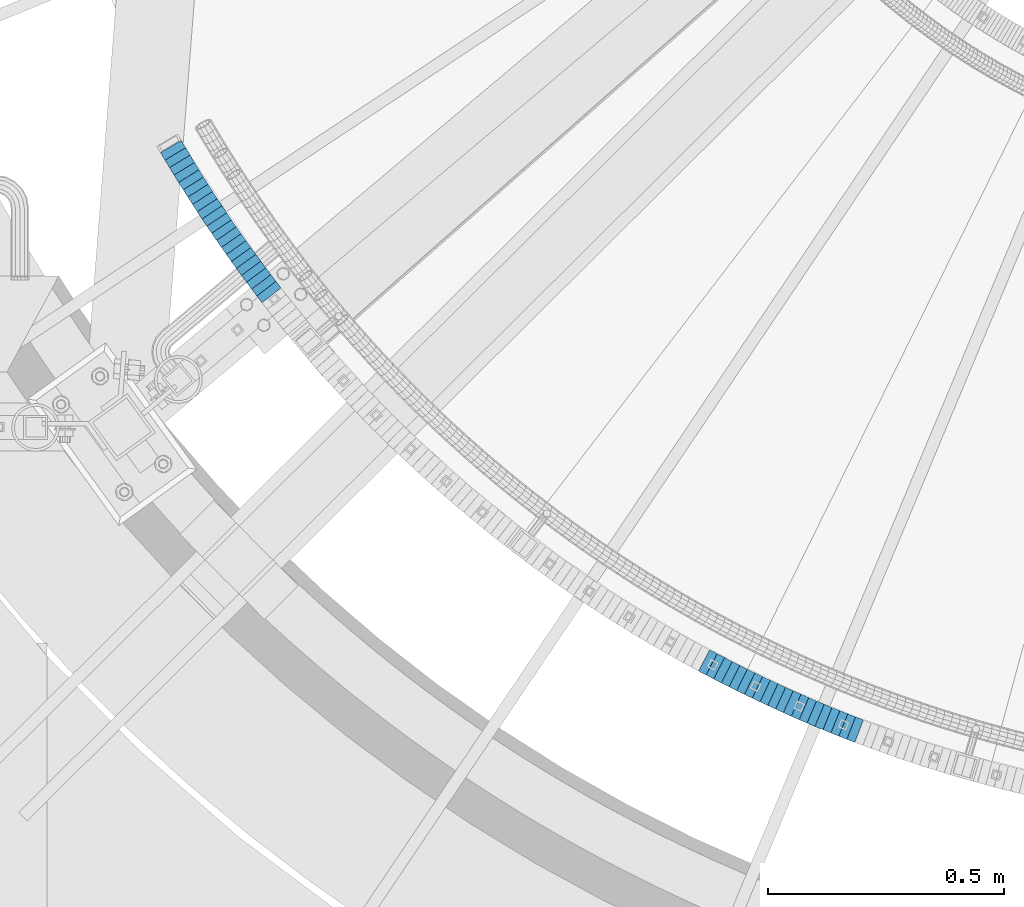
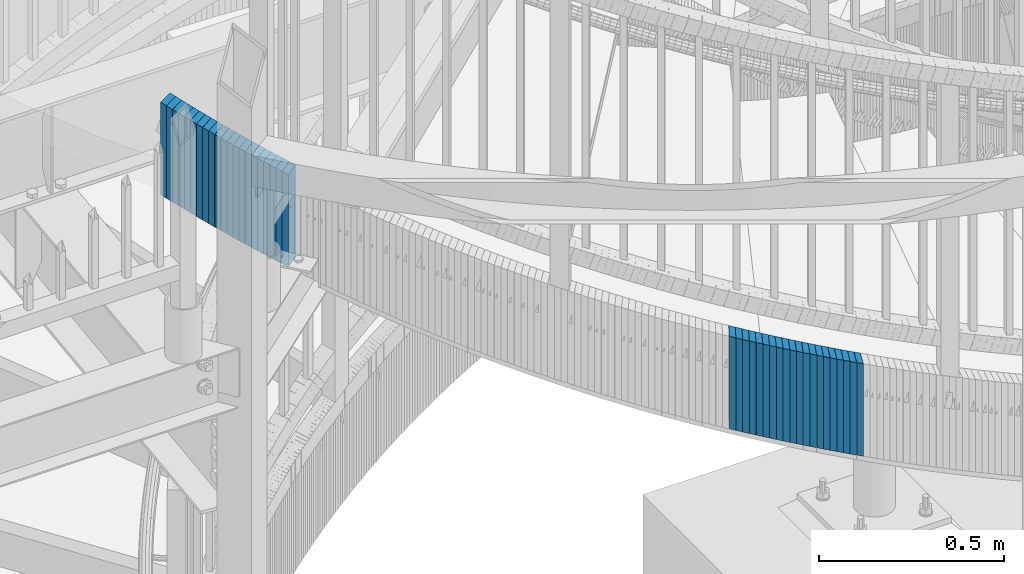
# One storey, part 874 of 975: 41 plates.
"""IFC2X3 building model written with IfcOpenShell, lengths in millimetres."""

from ifc_helpers import new_model, si_unit, frame, origin_with_axes, place, context, subcontext, project, spatial, faceted_brep, material, type_object, element, save


model = new_model("IFC2X3")

# Units and contexts
model_context = context("Model", 3, precision=1e-05, world=origin_with_axes())
body_context = subcontext(model_context, "Body", "Model", "MODEL_VIEW")
ifc_project = project(units=[si_unit("LENGTHUNIT", "METRE", prefix="MILLI"), si_unit("AREAUNIT", "SQUARE_METRE"), si_unit("VOLUMEUNIT", "CUBIC_METRE"), si_unit("MASSUNIT", "GRAM", prefix="KILO"), si_unit("TIMEUNIT", "SECOND"), si_unit("PLANEANGLEUNIT", "RADIAN"), si_unit("SOLIDANGLEUNIT", "STERADIAN"), si_unit("THERMODYNAMICTEMPERATUREUNIT", "DEGREE_CELSIUS"), si_unit("LUMINOUSINTENSITYUNIT", "LUMEN")], contexts=[model_context])

# Site, building, storey
site_placement = place(None, origin_with_axes())
site = spatial("IfcSite", under=ifc_project, at=site_placement, CompositionType="ELEMENT")
building_placement = place(site_placement, origin_with_axes())
building = spatial("IfcBuilding", under=site, at=building_placement, Name="Undefined", CompositionType="ELEMENT")
storey_placement = place(building_placement, origin_with_axes())
storey = spatial("IfcBuildingStorey", under=building, at=storey_placement, Name="Undefined", CompositionType="ELEMENT", Elevation=0.0)

# Plates
ifc_material = material(Name="STEEL/A36")
plate_type = type_object("IfcPlateType", PredefinedType="NOTDEFINED")
plate_1_placement = place(storey_placement, frame((32263.2377787819, 1943.35707548611, 4008.98750006769), z_axis=(-0.50965216587828, 0.860380537794515, 0.0), x_axis=(0.0, 0.0, 1.0)))
element("IfcPlate", 1, at=plate_1_placement, inside=storey, type_object=plate_type, material=ifc_material, Name="WALL", context=body_context, shape_type="Brep", body=[
    faceted_brep([(0.0, -25.3999999999724, -1.81898940354586e-11), (5.80000019073486, -25.3999999999614, 18.2477397918483), (5.80000019073486, 25.3999999999905, 18.247739791881), (0.0, 25.3999999999869, 1.45519152283669e-11), (310.600006103516, -25.3999999999614, 18.2477397918483), (310.600006103516, 25.3999999999905, 18.247739791881), (304.799987792969, -25.3999999999724, -1.81898940354586e-11), (304.799987792969, 25.3999999999869, 1.45519152283669e-11)], [[[0, 1, 2, 3]], [[1, 4, 5, 2]], [[4, 6, 7, 5]], [[6, 0, 3, 7]], [[5, 7, 3, 2]], [[6, 4, 1, 0]]]),
])
plate_2_placement = place(storey_placement, frame((32272.5741913029, 1927.69580112762, 4003.08750006769), z_axis=(-0.512064542174761, 0.858946974293147, 0.0), x_axis=(0.0, 0.0, 1.0)))
element("IfcPlate", 2, at=plate_2_placement, inside=storey, type_object=plate_type, material=ifc_material, Name="WALL", context=body_context, shape_type="Brep", body=[
    faceted_brep([(0.0, -25.3999999999724, -1.81898940354586e-11), (5.90000009536743, -25.4000000000233, 18.1617736816479), (5.90000009536743, 25.4000000000451, 18.1617736816097), (0.0, 25.3999999999869, 1.45519152283669e-11), (310.700012207032, -25.4000000000233, 18.1617736816479), (310.700012207032, 25.4000000000451, 18.1617736816097), (304.799987792969, -25.3999999999724, -1.81898940354586e-11), (304.799987792969, 25.3999999999869, 1.45519152283669e-11)], [[[0, 1, 2, 3]], [[1, 4, 5, 2]], [[4, 6, 7, 5]], [[6, 0, 3, 7]], [[5, 7, 3, 2]], [[6, 4, 1, 0]]]),
])
plate_3_placement = place(storey_placement, frame((32282.2353726493, 1911.92916422109, 3997.28750006769), z_axis=(-0.522562058163781, 0.852601252267221, 0.0), x_axis=(0.0, 0.0, 1.0)))
element("IfcPlate", 3, at=plate_3_placement, inside=storey, type_object=plate_type, material=ifc_material, Name="WALL", context=body_context, shape_type="Brep", body=[
    faceted_brep([(0.0, -25.3999999999724, -1.81898940354586e-11), (5.80000019073486, -25.3999999999687, 18.1796588897505), (5.80000019073486, 25.4000000000233, 18.1796588897596), (0.0, 25.3999999999869, 1.45519152283669e-11), (310.600006103515, -25.3999999999687, 18.1796588897505), (310.600006103515, 25.4000000000233, 18.1796588897596), (304.799987792969, -25.3999999999724, -1.81898940354586e-11), (304.799987792969, 25.3999999999869, 1.45519152283669e-11)], [[[0, 1, 2, 3]], [[1, 4, 5, 2]], [[4, 6, 7, 5]], [[6, 0, 3, 7]], [[5, 7, 3, 2]], [[6, 4, 1, 0]]]),
])
plate_4_placement = place(storey_placement, frame((32291.7737951276, 1896.46667760776, 3991.48750006769), z_axis=(-0.525022161079993, 0.851088556129674, 0.0), x_axis=(0.0, 0.0, 1.0)))
element("IfcPlate", 4, at=plate_4_placement, inside=storey, type_object=plate_type, material=ifc_material, Name="WALL", context=body_context, shape_type="Brep", body=[
    faceted_brep([(0.0, -25.3999999999724, -1.81898940354586e-11), (5.80000019073486, -25.4000000000124, 18.0944747924914), (5.80000019073486, 25.4000000000015, 18.0944747924805), (0.0, 25.3999999999869, 1.45519152283669e-11), (310.600006103516, -25.4000000000124, 18.0944747924914), (310.600006103516, 25.4000000000015, 18.0944747924805), (304.799987792969, -25.3999999999724, -1.81898940354586e-11), (304.799987792969, 25.3999999999869, 1.45519152283669e-11)], [[[0, 1, 2, 3]], [[1, 4, 5, 2]], [[4, 6, 7, 5]], [[6, 0, 3, 7]], [[5, 7, 3, 2]], [[6, 4, 1, 0]]]),
])
plate_5_placement = place(storey_placement, frame((32301.4760215312, 1881.00236729102, 3985.68750006769), z_axis=(-0.531491071246833, 0.847063894393388, 0.0), x_axis=(0.0, 0.0, 1.0)))
element("IfcPlate", 5, at=plate_5_placement, inside=storey, type_object=plate_type, material=ifc_material, Name="WALL", context=body_context, shape_type="Brep", body=[
    faceted_brep([(0.0, -25.3999999999724, -1.81898940354586e-11), (5.80000019073486, -25.4000000000378, 18.0623912811516), (5.80000019073486, 25.4000000000051, 18.0623912811207), (0.0, 25.3999999999869, 1.45519152283669e-11), (310.600006103516, -25.4000000000378, 18.0623912811516), (310.600006103516, 25.4000000000051, 18.0623912811207), (304.799987792969, -25.3999999999724, -1.81898940354586e-11), (304.799987792969, 25.3999999999869, 1.45519152283669e-11)], [[[0, 1, 2, 3]], [[1, 4, 5, 2]], [[4, 6, 7, 5]], [[6, 0, 3, 7]], [[5, 7, 3, 2]], [[6, 4, 1, 0]]]),
])
plate_6_placement = place(storey_placement, frame((32311.2393800325, 1865.60191210266, 3979.88750006769), z_axis=(-0.535445999966163, 0.844569464946629, 0.0), x_axis=(0.0, 0.0, 1.0)))
element("IfcPlate", 6, at=plate_6_placement, inside=storey, type_object=plate_type, material=ifc_material, Name="WALL", context=body_context, shape_type="Brep", body=[
    faceted_brep([(0.0, -25.3999999999724, -1.81898940354586e-11), (5.80000019073486, -25.3999999999614, 18.115739822355), (5.80000019073486, 25.3999999999833, 18.115739822395), (0.0, 25.3999999999869, 1.45519152283669e-11), (310.600006103516, -25.3999999999614, 18.115739822355), (310.600006103516, 25.3999999999833, 18.115739822395), (304.799987792969, -25.3999999999724, -1.81898940354586e-11), (304.799987792969, 25.3999999999869, 1.45519152283669e-11)], [[[0, 1, 2, 3]], [[1, 4, 5, 2]], [[4, 6, 7, 5]], [[6, 0, 3, 7]], [[5, 7, 3, 2]], [[6, 4, 1, 0]]]),
])
plate_7_placement = place(storey_placement, frame((32320.9798611505, 1850.33826958562, 3974.08750006769), z_axis=(-0.537951610922799, 0.842975719879028, 0.0), x_axis=(0.0, 0.0, 1.0)))
element("IfcPlate", 7, at=plate_7_placement, inside=storey, type_object=plate_type, material=ifc_material, Name="WALL", context=body_context, shape_type="Brep", body=[
    faceted_brep([(0.0, -25.3999999999724, -1.81898940354586e-11), (5.80000019073486, -25.4000000000196, 18.0313606262353), (5.80000019073486, 25.3999999999905, 18.0313606262353), (0.0, 25.3999999999869, 1.45519152283669e-11), (310.600006103516, -25.4000000000196, 18.0313606262353), (310.600006103516, 25.3999999999905, 18.0313606262353), (304.799987792969, -25.3999999999724, -1.81898940354586e-11), (304.799987792969, 25.3999999999869, 1.45519152283669e-11)], [[[0, 1, 2, 3]], [[1, 4, 5, 2]], [[4, 6, 7, 5]], [[6, 0, 3, 7]], [[5, 7, 3, 2]], [[6, 4, 1, 0]]]),
])
for number, where, z_axis, x_axis, name in (
    (8, (32331.0497800704, 1834.97558639288, 3968.28750006769), (-0.548293468925575, 0.836285998886482, 0.0), (0.0, 0.0, 1.0), "WALL"),
    (9, (32340.9497800771, 1819.87558639365, 3962.48750006769), (-0.548293468925575, 0.836285998886482, 0.0), (0.0, 0.0, 1.0), "WALL"),
):
    element("IfcPlate", number, at=place(storey_placement, frame(where, z_axis=z_axis, x_axis=x_axis)), inside=storey, type_object=plate_type, material=ifc_material, Name=name, context=body_context, shape_type="Brep", body=[
        faceted_brep([(0.0, -25.3999999999724, -1.81898940354586e-11), (5.80000019073486, -25.4000000000378, 18.0623912811516), (5.80000019073486, 25.4000000000051, 18.0623912811207), (0.0, 25.3999999999869, 1.45519152283669e-11), (310.600006103516, -25.4000000000378, 18.0623912811516), (310.600006103516, 25.4000000000051, 18.0623912811207), (304.799987792969, -25.3999999999724, -1.81898940354586e-11), (304.799987792969, 25.3999999999869, 1.45519152283669e-11)], [[[0, 1, 2, 3]], [[1, 4, 5, 2]], [[4, 6, 7, 5]], [[6, 0, 3, 7]], [[5, 7, 3, 2]], [[6, 4, 1, 0]]]),
    ])
plate_8_placement = place(storey_placement, frame((32350.9355483933, 1804.8456384251, 3956.68750006769), z_axis=(-0.553409530714104, 0.832909293569711, 0.0), x_axis=(0.0, 0.0, 1.0)))
element("IfcPlate", 10, at=plate_8_placement, inside=storey, type_object=plate_type, material=ifc_material, Name="WALL", context=body_context, shape_type="Brep", body=[
    faceted_brep([(0.0, -25.3999999999724, -1.81898940354586e-11), (5.80000019073486, -25.4000000000451, 17.8891029358201), (5.80000019073486, 25.4000000000087, 17.8891029357856), (0.0, 25.3999999999869, 1.45519152283669e-11), (310.600006103516, -25.4000000000451, 17.8891029358201), (310.600006103516, 25.4000000000087, 17.8891029357856), (304.799987792969, -25.3999999999724, -1.81898940354586e-11), (304.799987792969, 25.3999999999869, 1.45519152283669e-11)], [[[0, 1, 2, 3]], [[1, 4, 5, 2]], [[4, 6, 7, 5]], [[6, 0, 3, 7]], [[5, 7, 3, 2]], [[6, 4, 1, 0]]]),
])
plate_9_placement = place(storey_placement, frame((32361.1665378131, 1789.7504581367, 3950.98750006769), z_axis=(-0.561093794018155, 0.827752230026783, 0.0), x_axis=(0.0, 0.0, 1.0)))
element("IfcPlate", 11, at=plate_9_placement, inside=storey, type_object=plate_type, material=ifc_material, Name="WALL", context=body_context, shape_type="Brep", body=[
    faceted_brep([(0.0, -25.3999999999724, -1.81898940354586e-11), (5.69999980926514, -25.4000000000051, 18.0005550384485), (5.69999980926514, 25.3999999999978, 18.0005550384521), (0.0, 25.3999999999869, 1.45519152283669e-11), (310.5, -25.4000000000051, 18.0005550384485), (310.5, 25.3999999999978, 18.0005550384521), (304.799987792969, -25.3999999999724, -1.81898940354586e-11), (304.799987792969, 25.3999999999869, 1.45519152283669e-11)], [[[0, 1, 2, 3]], [[1, 4, 5, 2]], [[4, 6, 7, 5]], [[6, 0, 3, 7]], [[5, 7, 3, 2]], [[6, 4, 1, 0]]]),
])
plate_10_placement = place(storey_placement, frame((32371.3112700105, 1774.88468903055, 3945.18750006769), z_axis=(-0.563683128932899, 0.825991119901671, 0.0), x_axis=(0.0, 0.0, 1.0)))
element("IfcPlate", 12, at=plate_10_placement, inside=storey, type_object=plate_type, material=ifc_material, Name="WALL", context=body_context, shape_type="Brep", body=[
    faceted_brep([(0.0, -25.3999999999724, -1.81898940354586e-11), (5.80000019073486, -25.4000000000233, 17.9178676605334), (5.80000019073486, 25.3999999999942, 17.9178676605297), (0.0, 25.3999999999869, 1.45519152283669e-11), (310.600006103516, -25.4000000000233, 17.9178676605334), (310.600006103516, 25.3999999999942, 17.9178676605297), (304.799987792969, -25.3999999999724, -1.81898940354586e-11), (304.799987792969, 25.3999999999869, 1.45519152283669e-11)], [[[0, 1, 2, 3]], [[1, 4, 5, 2]], [[4, 6, 7, 5]], [[6, 0, 3, 7]], [[5, 7, 3, 2]], [[6, 4, 1, 0]]]),
])
plate_11_placement = place(storey_placement, frame((32381.6231063712, 1760.02216918971, 3939.48750006769), z_axis=(-0.570081547875678, 0.821588113820832, 0.0), x_axis=(0.0, 0.0, 1.0)))
element("IfcPlate", 13, at=plate_11_placement, inside=storey, type_object=plate_type, material=ifc_material, Name="WALL", context=body_context, shape_type="Brep", body=[
    faceted_brep([(0.0, -25.3999999999724, -1.81898940354586e-11), (5.69999980926514, -25.3999999999614, 17.8921775817616), (5.69999980926514, 25.400000000016, 17.8921775817726), (0.0, 25.3999999999869, 1.45519152283669e-11), (310.5, -25.3999999999614, 17.8921775817616), (310.5, 25.400000000016, 17.8921775817726), (304.799987792969, -25.3999999999724, -1.81898940354586e-11), (304.799987792969, 25.3999999999869, 1.45519152283669e-11)], [[[0, 1, 2, 3]], [[1, 4, 5, 2]], [[4, 6, 7, 5]], [[6, 0, 3, 7]], [[5, 7, 3, 2]], [[6, 4, 1, 0]]]),
])
plate_12_placement = place(storey_placement, frame((32391.9896039156, 1745.22680122843, 3933.68750006769), z_axis=(-0.573836192016333, 0.818970100023312, 0.0), x_axis=(0.0, 0.0, 1.0)))
element("IfcPlate", 14, at=plate_12_placement, inside=storey, type_object=plate_type, material=ifc_material, Name="WALL", context=body_context, shape_type="Brep", body=[
    faceted_brep([(0.0, -25.3999999999724, -1.81898940354586e-11), (5.80000019073486, -25.399999999976, 17.9493732452247), (5.80000019073486, 25.4000000000051, 17.9493732452393), (0.0, 25.3999999999869, 1.45519152283669e-11), (310.600006103516, -25.399999999976, 17.9493732452247), (310.600006103516, 25.4000000000051, 17.9493732452393), (304.799987792969, -25.3999999999724, -1.81898940354586e-11), (304.799987792969, 25.3999999999869, 1.45519152283669e-11)], [[[0, 1, 2, 3]], [[1, 4, 5, 2]], [[4, 6, 7, 5]], [[6, 0, 3, 7]], [[5, 7, 3, 2]], [[6, 4, 1, 0]]]),
])
for number, where, z_axis, x_axis, name in (
    (15, (32402.5515073453, 1730.49842355585, 3927.98750006769), (-0.582827439183217, 0.812595948879351, 7.00201781000943e-11), (0.0, 0.0, 1.0), "WALL"),
    (16, (32412.9515073392, 1715.99842355673, 3922.28750006769), (-0.582827439183217, 0.812595948879351, 7.00201781000943e-11), (0.0, 0.0, 1.0), "WALL"),
):
    element("IfcPlate", number, at=place(storey_placement, frame(where, z_axis=z_axis, x_axis=x_axis)), inside=storey, type_object=plate_type, material=ifc_material, Name=name, context=body_context, shape_type="Brep", body=[
        faceted_brep([(0.0, -25.3999999999724, -1.81898940354586e-11), (5.69999980926514, -25.3999999999651, 17.8440475463649), (5.69999980926514, 25.3999999999942, 17.8440475463904), (0.0, 25.3999999999869, 1.45519152283669e-11), (310.5, -25.3999999999651, 17.8440475463649), (310.5, 25.3999999999942, 17.8440475463904), (304.799987792969, -25.3999999999724, -1.81898940354586e-11), (304.799987792969, 25.3999999999869, 1.45519152283669e-11)], [[[0, 1, 2, 3]], [[1, 4, 5, 2]], [[4, 6, 7, 5]], [[6, 0, 3, 7]], [[5, 7, 3, 2]], [[6, 4, 1, 0]]]),
    ])
plate_13_placement = place(storey_placement, frame((32423.735887595, 1701.34467783482, 3916.58750006769), z_axis=(-0.592817428097409, 0.805336884132332, 0.0), x_axis=(0.0, 0.0, 1.0)))
element("IfcPlate", 17, at=plate_13_placement, inside=storey, type_object=plate_type, material=ifc_material, Name="WALL", context=body_context, shape_type="Brep", body=[
    faceted_brep([(0.0, -25.3999999999724, -1.81898940354586e-11), (5.69999980926514, -25.3999999999687, 17.8807163238307), (5.69999980926514, 25.400000000016, 17.880716323838), (0.0, 25.3999999999869, 1.45519152283669e-11), (310.5, -25.3999999999687, 17.8807163238307), (310.5, 25.400000000016, 17.880716323838), (304.799987792969, -25.3999999999724, -1.81898940354586e-11), (304.799987792969, 25.3999999999869, 1.45519152283669e-11)], [[[0, 1, 2, 3]], [[1, 4, 5, 2]], [[4, 6, 7, 5]], [[6, 0, 3, 7]], [[5, 7, 3, 2]], [[6, 4, 1, 0]]]),
])
plate_14_placement = place(storey_placement, frame((32434.3861484832, 1686.97663649873, 3910.78750006769), z_axis=(-0.595496220844773, 0.80335810879059, 0.0), x_axis=(0.0, 0.0, 1.0)))
element("IfcPlate", 18, at=plate_14_placement, inside=storey, type_object=plate_type, material=ifc_material, Name="WALL", context=body_context, shape_type="Brep", body=[
    faceted_brep([(0.0, -25.3999999999724, -1.81898940354586e-11), (5.80000019073486, -25.4000000000124, 17.8002815246691), (5.80000019073486, 25.4000000000051, 17.8002815246546), (0.0, 25.3999999999869, 1.45519152283669e-11), (310.600006103516, -25.4000000000124, 17.8002815246691), (310.600006103516, 25.4000000000051, 17.8002815246546), (304.799987792969, -25.3999999999724, -1.81898940354586e-11), (304.799987792969, 25.3999999999869, 1.45519152283669e-11)], [[[0, 1, 2, 3]], [[1, 4, 5, 2]], [[4, 6, 7, 5]], [[6, 0, 3, 7]], [[5, 7, 3, 2]], [[6, 4, 1, 0]]]),
])
plate_15_placement = place(storey_placement, frame((32444.9861484776, 1672.67663649869, 3905.08750006769), z_axis=(-0.595496220844773, 0.80335810879059, 0.0), x_axis=(0.0, 0.0, 1.0)))
element("IfcPlate", 19, at=plate_15_placement, inside=storey, type_object=plate_type, material=ifc_material, Name="WALL", context=body_context, shape_type="Brep", body=[
    faceted_brep([(0.0, -25.3999999999724, -1.81898940354586e-11), (5.69999980926514, -25.4000000000196, 17.8002815246764), (5.69999980926514, 25.4000000000015, 17.8002815246618), (0.0, 25.3999999999869, 1.45519152283669e-11), (310.5, -25.4000000000196, 17.8002815246764), (310.5, 25.4000000000015, 17.8002815246618), (304.799987792969, -25.3999999999724, -1.81898940354586e-11), (304.799987792969, 25.3999999999869, 1.45519152283669e-11)], [[[0, 1, 2, 3]], [[1, 4, 5, 2]], [[4, 6, 7, 5]], [[6, 0, 3, 7]], [[5, 7, 3, 2]], [[6, 4, 1, 0]]]),
])
for number, where, z_axis, x_axis, name in (
    (20, (32456.0269395398, 1658.25708780837, 3899.38750006769), (-0.608076877922584, 0.79387814589893, 0.0), (0.0, 0.0, 1.0), "WALL"),
    (21, (32466.8269395445, 1644.15708780927, 3893.68750006769), (-0.608076877922584, 0.79387814589893, 0.0), (0.0, 0.0, 1.0), "WALL"),
):
    element("IfcPlate", number, at=place(storey_placement, frame(where, z_axis=z_axis, x_axis=x_axis)), inside=storey, type_object=plate_type, material=ifc_material, Name=name, context=body_context, shape_type="Brep", body=[
        faceted_brep([(0.0, -25.3999999999724, -1.81898940354586e-11), (5.69999980926514, -25.3999999999542, 17.7609119415029), (5.69999980926514, 25.4000000000051, 17.7609119415283), (0.0, 25.3999999999869, 1.45519152283669e-11), (310.5, -25.3999999999542, 17.7609119415029), (310.5, 25.4000000000051, 17.7609119415283), (304.799987792969, -25.3999999999724, -1.81898940354586e-11), (304.799987792969, 25.3999999999869, 1.45519152283669e-11)], [[[0, 1, 2, 3]], [[1, 4, 5, 2]], [[4, 6, 7, 5]], [[6, 0, 3, 7]], [[5, 7, 3, 2]], [[6, 4, 1, 0]]]),
    ])
plate_16_placement = place(storey_placement, frame((33398.2790854262, 863.016063138942, 3504.3875000677), z_axis=(-0.885282574950683, 0.465053504974092, 0.0), x_axis=(0.0, 0.0, 1.0)))
element("IfcPlate", 22, at=plate_16_placement, inside=storey, type_object=plate_type, material=ifc_material, Name="WALL", context=body_context, shape_type="Brep", body=[
    faceted_brep([(0.0, -25.3999999999724, -1.81898940354586e-11), (5.69999980926514, -25.4000000000196, 17.8538513183848), (5.69999980926514, 25.4000000000415, 17.8538513183157), (0.0, 25.3999999999869, 1.45519152283669e-11), (310.5, -25.4000000000196, 17.8538513183848), (310.5, 25.4000000000415, 17.8538513183157), (304.799987792969, -25.3999999999724, -1.81898940354586e-11), (304.799987792969, 25.3999999999869, 1.45519152283669e-11)], [[[0, 1, 2, 3]], [[1, 4, 5, 2]], [[4, 6, 7, 5]], [[6, 0, 3, 7]], [[5, 7, 3, 2]], [[6, 4, 1, 0]]]),
])
plate_17_placement = place(storey_placement, frame((33414.2374284231, 854.685511041615, 3498.5875000677), z_axis=(-0.886485413411108, 0.462756536214603, 0.0), x_axis=(0.0, 0.0, 1.0)))
element("IfcPlate", 23, at=plate_17_placement, inside=storey, type_object=plate_type, material=ifc_material, Name="WALL", context=body_context, shape_type="Brep", body=[
    faceted_brep([(0.0, -25.3999999999724, -1.81898940354586e-11), (5.80000019073486, -25.3999999999614, 17.9424076079595), (5.80000019073486, 25.3999999999978, 17.9424076080322), (0.0, 25.3999999999869, 1.45519152283669e-11), (310.600006103516, -25.3999999999614, 17.9424076079595), (310.600006103516, 25.3999999999978, 17.9424076080322), (304.799987792969, -25.3999999999724, -1.81898940354586e-11), (304.799987792969, 25.3999999999869, 1.45519152283669e-11)], [[[0, 1, 2, 3]], [[1, 4, 5, 2]], [[4, 6, 7, 5]], [[6, 0, 3, 7]], [[5, 7, 3, 2]], [[6, 4, 1, 0]]]),
])
for number, where, z_axis, x_axis, name in (
    (24, (33430.2491479755, 846.427543789584, 3492.8875000677), (-0.88876758866203, 0.4583581278257, 0.0), (0.0, 0.0, 1.0), "WALL"),
    (25, (33446.5322191075, 838.283789884843, 3487.1875000677), (-0.894427191199916, 0.447213595099958, 0.0), (0.0, 0.0, 1.0), "WALL"),
):
    element("IfcPlate", number, at=place(storey_placement, frame(where, z_axis=z_axis, x_axis=x_axis)), inside=storey, type_object=plate_type, material=ifc_material, Name=name, context=body_context, shape_type="Brep", body=[
        faceted_brep([(0.0, -25.3999999999724, -1.81898940354586e-11), (5.69999980926514, -25.3999999999614, 17.8921775817616), (5.69999980926514, 25.400000000016, 17.8921775817726), (0.0, 25.3999999999869, 1.45519152283669e-11), (310.5, -25.3999999999614, 17.8921775817616), (310.5, 25.400000000016, 17.8921775817726), (304.799987792969, -25.3999999999724, -1.81898940354586e-11), (304.799987792969, 25.3999999999869, 1.45519152283669e-11)], [[[0, 1, 2, 3]], [[1, 4, 5, 2]], [[4, 6, 7, 5]], [[6, 0, 3, 7]], [[5, 7, 3, 2]], [[6, 4, 1, 0]]]),
    ])
plate_18_placement = place(storey_placement, frame((33462.6887676408, 830.255603483746, 3481.3875000677), z_axis=(-0.895536892069428, 0.444987275034499, 0.0), x_axis=(0.0, 0.0, 1.0)))
element("IfcPlate", 26, at=plate_18_placement, inside=storey, type_object=plate_type, material=ifc_material, Name="WALL", context=body_context, shape_type="Brep", body=[
    faceted_brep([(0.0, -25.3999999999724, -1.81898940354586e-11), (5.80000019073486, -25.3999999999505, 17.9788761138298), (5.80000019073486, 25.4000000000196, 17.9788761138625), (0.0, 25.3999999999869, 1.45519152283669e-11), (310.600006103516, -25.3999999999505, 17.9788761138298), (310.600006103516, 25.4000000000196, 17.9788761138625), (304.799987792969, -25.3999999999724, -1.81898940354586e-11), (304.799987792969, 25.3999999999869, 1.45519152283669e-11)], [[[0, 1, 2, 3]], [[1, 4, 5, 2]], [[4, 6, 7, 5]], [[6, 0, 3, 7]], [[5, 7, 3, 2]], [[6, 4, 1, 0]]]),
])
plate_19_placement = place(storey_placement, frame((33478.9024956787, 822.299446280344, 3475.5875000677), z_axis=(-0.897747805592998, 0.440509792800292, 0.0), x_axis=(0.0, 0.0, 1.0)))
element("IfcPlate", 27, at=plate_19_placement, inside=storey, type_object=plate_type, material=ifc_material, Name="WALL", context=body_context, shape_type="Brep", body=[
    faceted_brep([(0.0, -25.3999999999724, -1.81898940354586e-11), (5.80000019073486, -25.3999999999833, 17.9287471770986), (5.80000019073486, 25.4000000000087, 17.9287471771167), (0.0, 25.3999999999869, 1.45519152283669e-11), (310.600006103516, -25.3999999999833, 17.9287471770986), (310.600006103516, 25.4000000000087, 17.9287471771167), (304.799987792969, -25.3999999999724, -1.81898940354586e-11), (304.799987792969, 25.3999999999869, 1.45519152283669e-11)], [[[0, 1, 2, 3]], [[1, 4, 5, 2]], [[4, 6, 7, 5]], [[6, 0, 3, 7]], [[5, 7, 3, 2]], [[6, 4, 1, 0]]]),
])
plate_20_placement = place(storey_placement, frame((33495.1170648781, 814.443585333223, 3469.8875000677), z_axis=(-0.899947055462653, 0.435999194224142, 0.0), x_axis=(0.0, 0.0, 1.0)))
element("IfcPlate", 28, at=plate_20_placement, inside=storey, type_object=plate_type, material=ifc_material, Name="WALL", context=body_context, shape_type="Brep", body=[
    faceted_brep([(0.0, -25.3999999999724, -1.81898940354586e-11), (5.69999980926514, -25.3999999999614, 17.8921775817616), (5.69999980926514, 25.400000000016, 17.8921775817726), (0.0, 25.3999999999869, 1.45519152283669e-11), (310.5, -25.3999999999614, 17.8921775817616), (310.5, 25.400000000016, 17.8921775817726), (304.799987792969, -25.3999999999724, -1.81898940354586e-11), (304.799987792969, 25.3999999999869, 1.45519152283669e-11)], [[[0, 1, 2, 3]], [[1, 4, 5, 2]], [[4, 6, 7, 5]], [[6, 0, 3, 7]], [[5, 7, 3, 2]], [[6, 4, 1, 0]]]),
])
plate_21_placement = place(storey_placement, frame((33511.4876246874, 806.661736721061, 3464.1875000677), z_axis=(-0.903169441759062, 0.429284240885481, 0.0), x_axis=(0.0, 0.0, 1.0)))
element("IfcPlate", 29, at=plate_21_placement, inside=storey, type_object=plate_type, material=ifc_material, Name="WALL", context=body_context, shape_type="Brep", body=[
    faceted_brep([(0.0, -25.3999999999724, -1.81898940354586e-11), (5.69999980926514, -25.3999999999542, 17.9401779173968), (5.69999980926514, 25.3999999999924, 17.9401779175023), (0.0, 25.3999999999869, 1.45519152283669e-11), (310.5, -25.3999999999542, 17.9401779173968), (310.5, 25.3999999999924, 17.9401779175023), (304.799987792969, -25.3999999999724, -1.81898940354586e-11), (304.799987792969, 25.3999999999869, 1.45519152283669e-11)], [[[0, 1, 2, 3]], [[1, 4, 5, 2]], [[4, 6, 7, 5]], [[6, 0, 3, 7]], [[5, 7, 3, 2]], [[6, 4, 1, 0]]]),
])
plate_22_placement = place(storey_placement, frame((33527.8035510447, 799.00699414613, 3458.3875000677), z_axis=(-0.905324661250481, 0.42472021111751, 0.0), x_axis=(0.0, 0.0, 1.0)))
element("IfcPlate", 30, at=plate_22_placement, inside=storey, type_object=plate_type, material=ifc_material, Name="WALL", context=body_context, shape_type="Brep", body=[
    faceted_brep([(0.0, -25.3999999999724, -1.81898940354586e-11), (5.80000019073486, -25.4000000000451, 17.8891029358201), (5.80000019073486, 25.4000000000087, 17.8891029357856), (0.0, 25.3999999999869, 1.45519152283669e-11), (310.600006103516, -25.4000000000451, 17.8891029358201), (310.600006103516, 25.4000000000087, 17.8891029357856), (304.799987792969, -25.3999999999724, -1.81898940354586e-11), (304.799987792969, 25.3999999999869, 1.45519152283669e-11)], [[[0, 1, 2, 3]], [[1, 4, 5, 2]], [[4, 6, 7, 5]], [[6, 0, 3, 7]], [[5, 7, 3, 2]], [[6, 4, 1, 0]]]),
])
plate_23_placement = place(storey_placement, frame((33544.2743052284, 791.427658079768, 3452.6875000677), z_axis=(-0.908448128430405, 0.417997605198038, 0.0), x_axis=(0.0, 0.0, 1.0)))
element("IfcPlate", 31, at=plate_23_placement, inside=storey, type_object=plate_type, material=ifc_material, Name="WALL", context=body_context, shape_type="Brep", body=[
    faceted_brep([(0.0, -25.3999999999724, -1.81898940354586e-11), (5.69999980926514, -25.3999999999542, 17.9401779173968), (5.69999980926514, 25.3999999999924, 17.9401779175023), (0.0, 25.3999999999869, 1.45519152283669e-11), (310.5, -25.3999999999542, 17.9401779173968), (310.5, 25.3999999999924, 17.9401779175023), (304.799987792969, -25.3999999999724, -1.81898940354586e-11), (304.799987792969, 25.3999999999869, 1.45519152283669e-11)], [[[0, 1, 2, 3]], [[1, 4, 5, 2]], [[4, 6, 7, 5]], [[6, 0, 3, 7]], [[5, 7, 3, 2]], [[6, 4, 1, 0]]]),
])
plate_24_placement = place(storey_placement, frame((33560.5378877091, 783.998508349835, 3446.8875000677), z_axis=(-0.909595755607489, 0.415494357820705, 0.0), x_axis=(0.0, 0.0, 1.0)))
element("IfcPlate", 32, at=plate_24_placement, inside=storey, type_object=plate_type, material=ifc_material, Name="WALL", context=body_context, shape_type="Brep", body=[
    faceted_brep([(0.0, -25.3999999999724, -1.81898940354586e-11), (5.80000019073486, -25.3999999999542, 17.8084259032221), (5.80000019073486, 25.3999999999833, 17.8084259033567), (0.0, 25.3999999999869, 1.45519152283669e-11), (310.600006103516, -25.3999999999542, 17.8084259032221), (310.600006103516, 25.3999999999833, 17.8084259033567), (304.799987792969, -25.3999999999724, -1.81898940354586e-11), (304.799987792969, 25.3999999999869, 1.45519152283669e-11)], [[[0, 1, 2, 3]], [[1, 4, 5, 2]], [[4, 6, 7, 5]], [[6, 0, 3, 7]], [[5, 7, 3, 2]], [[6, 4, 1, 0]]]),
])
plate_25_placement = place(storey_placement, frame((33577.1624007158, 776.597265716418, 3441.1875000677), z_axis=(-0.913581686036451, 0.406655263016225, 0.0), x_axis=(0.0, 0.0, 1.0)))
element("IfcPlate", 33, at=plate_25_placement, inside=storey, type_object=plate_type, material=ifc_material, Name="WALL", context=body_context, shape_type="Brep", body=[
    faceted_brep([(0.0, -25.3999999999724, -1.81898940354586e-11), (5.69999980926514, -25.4000000000342, 17.9493732452938), (5.69999980926514, 25.4000000000415, 17.9493732451738), (0.0, 25.3999999999869, 1.45519152283669e-11), (310.5, -25.4000000000342, 17.9493732452938), (310.5, 25.4000000000415, 17.9493732451738), (304.799987792969, -25.3999999999724, -1.81898940354586e-11), (304.799987792969, 25.3999999999869, 1.45519152283669e-11)], [[[0, 1, 2, 3]], [[1, 4, 5, 2]], [[4, 6, 7, 5]], [[6, 0, 3, 7]], [[5, 7, 3, 2]], [[6, 4, 1, 0]]]),
])
plate_26_placement = place(storey_placement, frame((33593.68089681, 769.344882176379, 3435.4875000677), z_axis=(-0.91564403017333, 0.401990062076095, 0.0), x_axis=(0.0, 0.0, 1.0)))
element("IfcPlate", 34, at=plate_26_placement, inside=storey, type_object=plate_type, material=ifc_material, Name="WALL", context=body_context, shape_type="Brep", body=[
    faceted_brep([(0.0, -25.3999999999724, -1.81898940354586e-11), (5.69999980926514, -25.4000000000633, 17.9075393677485), (5.69999980926514, 25.3999999999905, 17.9075393676903), (0.0, 25.3999999999869, 1.45519152283669e-11), (310.5, -25.4000000000633, 17.9075393677485), (310.5, 25.3999999999905, 17.9075393676903), (304.799987792969, -25.3999999999724, -1.81898940354586e-11), (304.799987792969, 25.3999999999869, 1.45519152283669e-11)], [[[0, 1, 2, 3]], [[1, 4, 5, 2]], [[4, 6, 7, 5]], [[6, 0, 3, 7]], [[5, 7, 3, 2]], [[6, 4, 1, 0]]]),
])
plate_27_placement = place(storey_placement, frame((33610.320288361, 762.241246398534, 3429.6875000677), z_axis=(-0.919724178945735, 0.392565197976837, 0.0), x_axis=(0.0, 0.0, 1.0)))
element("IfcPlate", 35, at=plate_27_placement, inside=storey, type_object=plate_type, material=ifc_material, Name="WALL", context=body_context, shape_type="Brep", body=[
    faceted_brep([(0.0, -25.3999999999724, -1.81898940354586e-11), (5.80000019073486, -25.3999999999796, 17.8280677795228), (5.80000019073486, 25.4000000000196, 17.8280677795265), (0.0, 25.3999999999869, 1.45519152283669e-11), (310.600006103516, -25.3999999999796, 17.8280677795228), (310.600006103516, 25.4000000000196, 17.8280677795265), (304.799987792969, -25.3999999999724, -1.81898940354586e-11), (304.799987792969, 25.3999999999869, 1.45519152283669e-11)], [[[0, 1, 2, 3]], [[1, 4, 5, 2]], [[4, 6, 7, 5]], [[6, 0, 3, 7]], [[5, 7, 3, 2]], [[6, 4, 1, 0]]]),
])
plate_28_placement = place(storey_placement, frame((33626.7202883639, 755.241246399464, 3423.9875000677), z_axis=(-0.919724178945735, 0.392565197976837, 0.0), x_axis=(0.0, 0.0, 1.0)))
element("IfcPlate", 36, at=plate_28_placement, inside=storey, type_object=plate_type, material=ifc_material, Name="WALL", context=body_context, shape_type="Brep", body=[
    faceted_brep([(0.0, -25.3999999999724, -1.81898940354586e-11), (5.69999980926514, -25.3999999999724, 17.833955764745), (5.69999980926514, 25.3999999999905, 17.8339557647923), (0.0, 25.3999999999869, 1.45519152283669e-11), (310.5, -25.3999999999724, 17.833955764745), (310.5, 25.3999999999905, 17.8339557647923), (304.799987792969, -25.3999999999724, -1.81898940354586e-11), (304.799987792969, 25.3999999999869, 1.45519152283669e-11)], [[[0, 1, 2, 3]], [[1, 4, 5, 2]], [[4, 6, 7, 5]], [[6, 0, 3, 7]], [[5, 7, 3, 2]], [[6, 4, 1, 0]]]),
])
plate_29_placement = place(storey_placement, frame((33643.5132413538, 748.318365526468, 3418.2875000677), z_axis=(-0.924562008594262, 0.381031615832787, 0.0), x_axis=(0.0, 0.0, 1.0)))
element("IfcPlate", 37, at=plate_29_placement, inside=storey, type_object=plate_type, material=ifc_material, Name="WALL", context=body_context, shape_type="Brep", body=[
    faceted_brep([(0.0, -25.3999999999724, -1.81898940354586e-11), (5.69999980926514, -25.4000000000196, 17.8538513183848), (5.69999980926514, 25.4000000000415, 17.8538513183157), (0.0, 25.3999999999869, 1.45519152283669e-11), (310.5, -25.4000000000196, 17.8538513183848), (310.5, 25.4000000000415, 17.8538513183157), (304.799987792969, -25.3999999999724, -1.81898940354586e-11), (304.799987792969, 25.3999999999869, 1.45519152283669e-11)], [[[0, 1, 2, 3]], [[1, 4, 5, 2]], [[4, 6, 7, 5]], [[6, 0, 3, 7]], [[5, 7, 3, 2]], [[6, 4, 1, 0]]]),
])
plate_30_placement = place(storey_placement, frame((33660.1631445129, 741.497861356481, 3412.4875000677), z_axis=(-0.925369259401997, 0.379066925164674, 0.0), x_axis=(0.0, 0.0, 1.0)))
element("IfcPlate", 38, at=plate_30_placement, inside=storey, type_object=plate_type, material=ifc_material, Name="WALL", context=body_context, shape_type="Brep", body=[
    faceted_brep([(0.0, -25.3999999999724, -1.81898940354586e-11), (5.80000019073486, -25.3999999999614, 17.9424076079595), (5.80000019073486, 25.3999999999978, 17.9424076080322), (0.0, 25.3999999999869, 1.45519152283669e-11), (310.600006103516, -25.3999999999614, 17.9424076079595), (310.600006103516, 25.3999999999978, 17.9424076080322), (304.799987792969, -25.3999999999724, -1.81898940354586e-11), (304.799987792969, 25.3999999999869, 1.45519152283669e-11)], [[[0, 1, 2, 3]], [[1, 4, 5, 2]], [[4, 6, 7, 5]], [[6, 0, 3, 7]], [[5, 7, 3, 2]], [[6, 4, 1, 0]]]),
])
for number, where, z_axis, x_axis, name in (
    (39, (33677.0071712779, 734.799371707472, 3406.7875000677), (-0.929246804682174, 0.369459572873636, 0.0), (0.0, 0.0, 1.0), "WALL"),
    (40, (33693.6071712809, 728.199371707577, 3401.0875000677), (-0.929246804682174, 0.369459572873636, 0.0), (0.0, 0.0, 1.0), "WALL"),
):
    element("IfcPlate", number, at=place(storey_placement, frame(where, z_axis=z_axis, x_axis=x_axis)), inside=storey, type_object=plate_type, material=ifc_material, Name=name, context=body_context, shape_type="Brep", body=[
        faceted_brep([(0.0, -25.3999999999724, -1.81898940354586e-11), (5.69999980926514, -25.4000000000378, 17.8639297485788), (5.69999980926514, 25.3999999999833, 17.8639297485533), (0.0, 25.3999999999869, 1.45519152283669e-11), (310.5, -25.4000000000378, 17.8639297485788), (310.5, 25.3999999999833, 17.8639297485533), (304.799987792969, -25.3999999999724, -1.81898940354586e-11), (304.799987792969, 25.3999999999869, 1.45519152283669e-11)], [[[0, 1, 2, 3]], [[1, 4, 5, 2]], [[4, 6, 7, 5]], [[6, 0, 3, 7]], [[5, 7, 3, 2]], [[6, 4, 1, 0]]]),
    ])
plate_31_placement = place(storey_placement, frame((33710.4542448225, 721.702629087643, 3395.3875000677), z_axis=(-0.933055569241503, 0.359732268093112, 0.0), x_axis=(0.0, 0.0, 1.0)))
element("IfcPlate", 41, at=plate_31_placement, inside=storey, type_object=plate_type, material=ifc_material, Name="WALL", context=body_context, shape_type="Brep", body=[
    faceted_brep([(0.0, -25.3999999999724, -1.81898940354586e-11), (5.69999980926514, -25.4000000000251, 17.7924137116061), (5.69999980926514, 25.4000000000051, 17.7924137115479), (0.0, 25.3999999999869, 1.45519152283669e-11), (310.5, -25.4000000000251, 17.7924137116061), (310.5, 25.4000000000051, 17.7924137115479), (304.799987792969, -25.3999999999724, -1.81898940354586e-11), (304.799987792969, 25.3999999999869, 1.45519152283669e-11)], [[[0, 1, 2, 3]], [[1, 4, 5, 2]], [[4, 6, 7, 5]], [[6, 0, 3, 7]], [[5, 7, 3, 2]], [[6, 4, 1, 0]]]),
])

save(model, "model.ifc")
